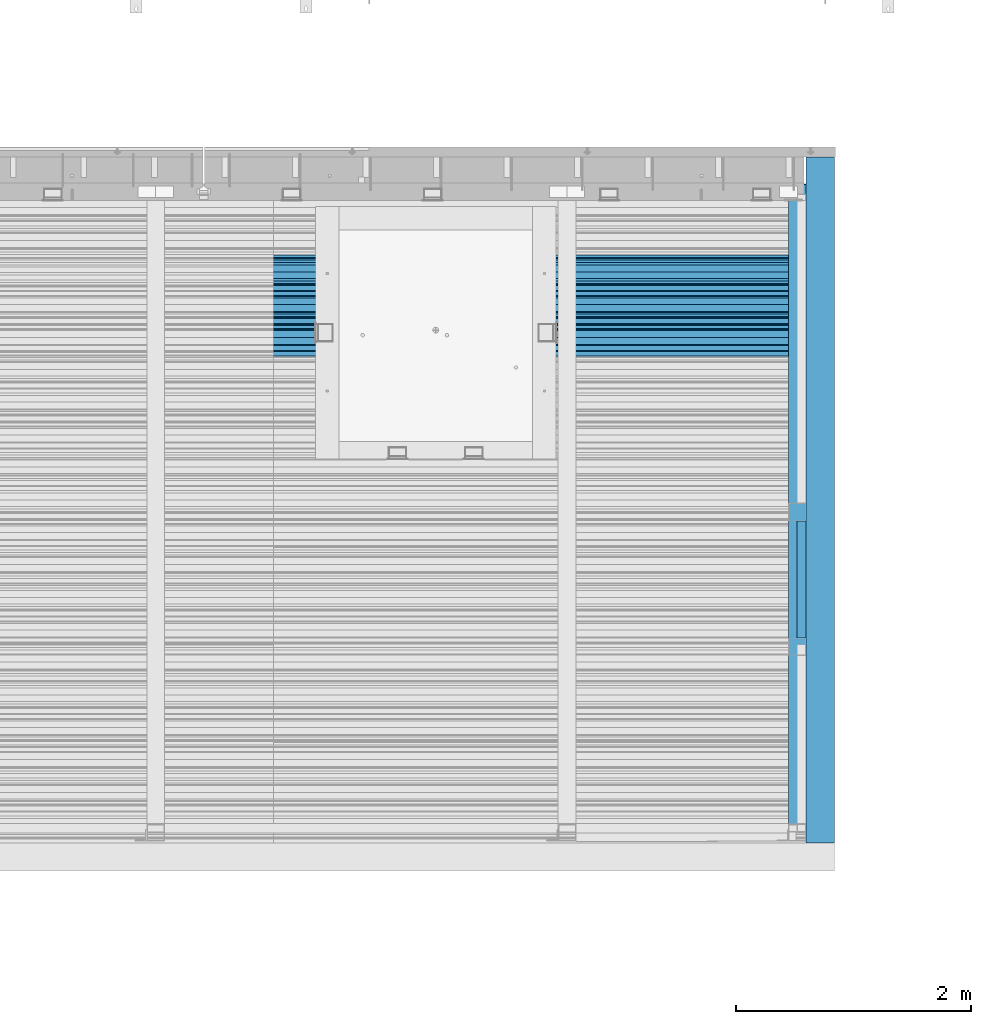
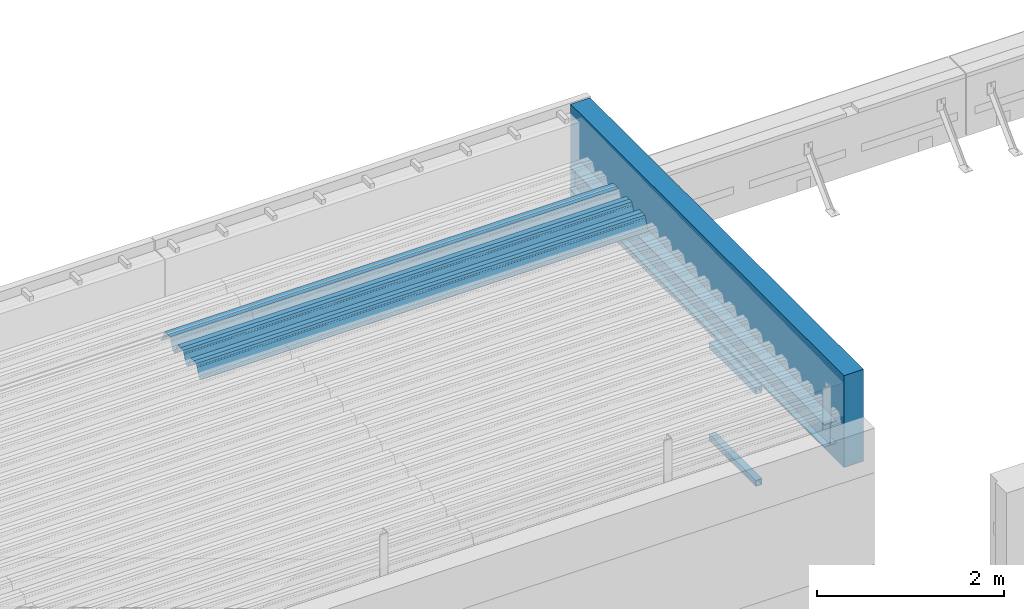
# One storey, part 41 of 153: 5 beams, 5 elements without a shape of their own.
"""IFC2X3 building model written with IfcOpenShell, lengths in millimetres."""

from ifc_helpers import new_model, si_unit, frame, origin_with_axes, place, context, subcontext, project, spatial, faceted_brep, material, type_object, element, aggregate, save


model = new_model("IFC2X3")

# Units and contexts
model_context = context("Model", 3, precision=1e-05, world=origin_with_axes())
body_context = subcontext(model_context, "Body", "Model", "MODEL_VIEW")
ifc_project = project(units=[si_unit("LENGTHUNIT", "METRE", prefix="MILLI"), si_unit("AREAUNIT", "SQUARE_METRE"), si_unit("VOLUMEUNIT", "CUBIC_METRE"), si_unit("MASSUNIT", "GRAM", prefix="KILO"), si_unit("TIMEUNIT", "SECOND"), si_unit("PLANEANGLEUNIT", "RADIAN"), si_unit("SOLIDANGLEUNIT", "STERADIAN"), si_unit("THERMODYNAMICTEMPERATUREUNIT", "DEGREE_CELSIUS"), si_unit("LUMINOUSINTENSITYUNIT", "LUMEN")], contexts=[model_context])

# Site, building, storey
site_placement = place(None, origin_with_axes())
site = spatial("IfcSite", under=ifc_project, at=site_placement, CompositionType="ELEMENT")
building_placement = place(site_placement, origin_with_axes())
building = spatial("IfcBuilding", under=site, at=building_placement, CompositionType="ELEMENT")
storey_placement = place(building_placement, origin_with_axes())
storey = spatial("IfcBuildingStorey", under=building, at=storey_placement, Name="8", CompositionType="ELEMENT", Elevation=0.0)

# Assembly, beam
assembly_1_placement = place(storey_placement, origin_with_axes())
assembly_1 = element("IfcElementAssembly", 1, at=assembly_1_placement, inside=storey, Name="Steel Assembly", AssemblyPlace="NOTDEFINED", PredefinedType="RIGID_FRAME")
ifc_material_1 = material(Name="STEEL/S355J2")
beam_type_1 = type_object("IfcBeamType", Name="80X80X4", PredefinedType="NOTDEFINED")
beam_1_placement = place(assembly_1_placement, frame((21747.0, 16710.0, 105115.0), z_axis=(0.0, 0.0, 1.0), x_axis=(0.0, 1.0, 0.0)))
beam_1 = element("IfcBeam", 2, at=beam_1_placement, type_object=beam_type_1, material=ifc_material_1, ObjectType="80X80X4", context=body_context, shape_type="Brep", body=[
    faceted_brep([(0.0, 36.0, -36.0), (0.0, -36.0, -36.0), (995.0, -36.0, -36.0), (995.0, 36.0, -36.0), (0.0, -36.0, 36.0), (995.0, -36.0, 36.0), (0.0, 36.0, 36.0), (995.0, 36.0, 36.0), (0.0, 40.0, -40.0), (0.0, 40.0, 40.0), (995.0, 40.0, 40.0), (995.0, 40.0, -40.0), (0.0, -40.0, 40.0), (995.0, -40.0, 40.0), (0.0, -40.0, -40.0), (995.0, -40.0, -40.0)], [[[0, 1, 2, 3]], [[1, 4, 5, 2]], [[4, 6, 7, 5]], [[6, 0, 3, 7]], [[8, 9, 10, 11]], [[9, 12, 13, 10]], [[12, 14, 15, 13]], [[14, 8, 11, 15]], [[13, 15, 11, 10], [5, 7, 3, 2]], [[14, 12, 9, 8], [6, 4, 1, 0]]]),
])
aggregate(assembly_1, [beam_1])

assembly_2_placement = place(storey_placement, origin_with_axes())
assembly_2 = element("IfcElementAssembly", 3, at=assembly_2_placement, inside=storey, Name="Steel Assembly", AssemblyPlace="NOTDEFINED", PredefinedType="RIGID_FRAME")
beam_2_placement = place(assembly_2_placement, frame((21747.0, 16710.0, 103915.0), z_axis=(0.0, 0.0, 1.0), x_axis=(0.0, 1.0, 0.0)))
beam_2 = element("IfcBeam", 4, at=beam_2_placement, type_object=beam_type_1, material=ifc_material_1, ObjectType="80X80X4", context=body_context, shape_type="Brep", body=[
    faceted_brep([(0.0, 36.0, -36.0), (0.0, -36.0, -36.0), (995.0, -36.0, -36.0), (995.0, 36.0, -36.0), (0.0, -36.0, 36.0), (995.0, -36.0, 36.0), (0.0, 36.0, 36.0), (995.0, 36.0, 36.0), (0.0, 40.0, -40.0), (0.0, 40.0, 40.0), (995.0, 40.0, 40.0), (995.0, 40.0, -40.0), (0.0, -40.0, 40.0), (995.0, -40.0, 40.0), (0.0, -40.0, -40.0), (995.0, -40.0, -40.0)], [[[0, 1, 2, 3]], [[1, 4, 5, 2]], [[4, 6, 7, 5]], [[6, 0, 3, 7]], [[8, 9, 10, 11]], [[9, 12, 13, 10]], [[12, 14, 15, 13]], [[14, 8, 11, 15]], [[13, 15, 11, 10], [5, 7, 3, 2]], [[14, 12, 9, 8], [6, 4, 1, 0]]]),
])
aggregate(assembly_2, [beam_2])

assembly_3_placement = place(storey_placement, origin_with_axes())
assembly_3 = element("IfcElementAssembly", 5, at=assembly_3_placement, inside=storey, Name="Steel Assembly", AssemblyPlace="NOTDEFINED", PredefinedType="RIGID_FRAME")
beam_type_2 = type_object("IfcBeamType", Name="IPE300", PredefinedType="NOTDEFINED")
beam_3_placement = place(assembly_3_placement, frame((21712.0, 15128.0908589965, 105518.668697995), z_axis=(0.0, -0.0124990270013869, 0.999921884110963), x_axis=(0.0, 0.999921884110963, 0.0124990270013883)))
beam_3 = element("IfcBeam", 6, at=beam_3_placement, type_object=beam_type_2, material=ifc_material_1, ObjectType="IPE300", context=body_context, shape_type="Brep", body=[
    faceted_brep([(3.63797880709171e-12, 75.0, -149.999999999985), (0.0, 75.0, -139.300000189993), (5440.87494889885, 75.0, -139.300000189993), (5440.87494889886, 75.0, -150.0), (0.0, 3.5499999525, -139.300000189993), (5440.87494889885, 3.5499999525, -139.300000189993), (0.0, 3.5499999525, 139.300000190022), (5440.87494889885, 3.5499999525, 139.300000190022), (0.0, 75.0, 139.300000190022), (5440.87494889885, 75.0, 139.300000190022), (3.63797880709171e-12, 75.0, 150.0), (5440.87494889885, 75.0, 150.0), (3.63797880709171e-12, -75.0, 150.0), (5440.87494889885, -75.0, 150.0), (0.0, -75.0, 139.300000190022), (5440.87494889885, -75.0, 139.300000190022), (0.0, -3.5499999525, 139.300000190022), (5440.87494889885, -3.5499999525, 139.300000190022), (0.0, -3.5499999525, -139.300000189993), (5440.87494889885, -3.5499999525, -139.300000189993), (0.0, -75.0, -139.300000189993), (5440.87494889885, -75.0, -139.300000189993), (3.63797880709171e-12, -75.0, -149.999999999985), (5440.87494889886, -75.0, -150.0)], [[[0, 1, 2, 3]], [[1, 4, 5, 2]], [[4, 6, 7, 5]], [[6, 8, 9, 7]], [[8, 10, 11, 9]], [[10, 12, 13, 11]], [[12, 14, 15, 13]], [[14, 16, 17, 15]], [[16, 18, 19, 17]], [[18, 20, 21, 19]], [[20, 22, 23, 21]], [[22, 0, 3, 23]], [[5, 7, 9, 11, 13, 15, 17, 19, 21, 23, 3, 2]], [[22, 20, 18, 16, 14, 12, 10, 8, 6, 4, 1, 0]]]),
])
aggregate(assembly_3, [beam_3])

assembly_4_placement = place(storey_placement, origin_with_axes())
assembly_4 = element("IfcElementAssembly", 7, at=assembly_4_placement, inside=storey, Name="Steel Assembly", AssemblyPlace="NOTDEFINED", PredefinedType="RIGID_FRAME")
beam_type_3 = type_object("IfcBeamType", Name="W", PredefinedType="NOTDEFINED")
beam_4_placement = place(assembly_4_placement, frame((21782.0, 19534.8848733159, 105801.771450287), z_axis=(0.0, -0.0124990270013869, 0.999921884110963), x_axis=(-1.0, 3.00000001838171e-08, 0.0)))
beam_4 = element("IfcBeam", 8, at=beam_4_placement, type_object=beam_type_3, material=ifc_material_1, ObjectType="W", context=body_context, shape_type="Brep", body=[
    faceted_brep([(0.0, -412.839996337891, -77.0100021362159), (0.0, -409.160003662109, -77.0100021362014), (5530.0, -409.160003662109, -77.0100021362014), (5530.0, -412.839996337891, -77.0100021362159), (0.0, -408.070007324222, -73.4800033569045), (5530.0, -408.070007324222, -73.4800033569045), (0.0, -400.339996337894, -48.0600013732619), (5530.0, -400.339996337894, -48.0600013732619), (0.0, -399.459991455082, -46.5600013732619), (5530.0, -399.459991455082, -46.5600013732619), (0.0, -390.329986572269, -36.5499992370314), (5530.0, -390.329986572269, -36.5499992370314), (0.0, -389.19000244141, -34.6300010680861), (5530.0, -389.19000244141, -34.6300010680861), (0.0, -367.820007324222, 35.3400001526024), (5530.0, -367.820007324222, 35.3400001526024), (0.0, -366.989990234379, 36.8499984741502), (5530.0, -366.989990234379, 36.8499984741502), (0.0, -357.809997558597, 46.8600006103807), (5530.0, -357.809997558597, 46.8600006103807), (0.0, -356.720001220707, 48.7700004577782), (5530.0, -356.720001220707, 48.7700004577782), (0.0, -349.309997558594, 73.1500015258935), (5530.0, -349.309997558594, 73.1500015258935), (0.0, -347.850006103516, 75.2300033569481), (5530.0, -347.850006103516, 75.2300033569481), (0.0, -345.470001220707, 76.010002136245), (5530.0, -345.470001220707, 76.010002136245), (0.0, -305.480010986332, 76.010002136245), (5530.0, -305.480010986332, 76.010002136245), (0.0, -304.279998779301, 75.8000030517578), (5530.0, -304.279998779301, 75.8000030517578), (0.0, -291.679992675785, 71.6999969482567), (5530.0, -291.679992675785, 71.6999969482567), (0.0, -290.179992675789, 71.2300033569481), (5530.0, -290.179992675789, 71.2300033569481), (0.0, -288.720001220707, 71.6999969482567), (5530.0, -288.720001220707, 71.6999969482567), (0.0, -276.119995117191, 75.8000030517869), (5530.0, -276.119995117191, 75.8000030517869), (0.0, -274.929992675785, 76.010002136245), (5530.0, -274.929992675785, 76.010002136245), (0.0, -234.94000244141, 76.010002136245), (5530.0, -234.94000244141, 76.010002136245), (0.0, -232.550003051758, 75.2300033569627), (5530.0, -232.550003051758, 75.2300033569627), (0.0, -231.100006103519, 73.1500015258935), (5530.0, -231.100006103519, 73.1500015258935), (0.0, -223.679992675785, 48.7700004577782), (5530.0, -223.679992675785, 48.7700004577782), (0.0, -222.589996337894, 46.8600006103661), (5530.0, -222.589996337894, 46.8600006103661), (0.0, -213.410003662113, 36.8499984741502), (5530.0, -213.410003662113, 36.8499984741502), (0.0, -212.529998779301, 35.3400001526024), (5530.0, -212.529998779301, 35.3400001526024), (0.0, -191.160003662109, -34.6300010681007), (5530.0, -191.160003662109, -34.6300010681007), (0.0, -190.070007324222, -36.5499992370605), (5530.0, -190.070007324222, -36.5499992370605), (0.0, -180.940002441406, -46.560001373291), (5530.0, -180.940002441406, -46.560001373291), (0.0, -180.059997558597, -48.0600013732619), (5530.0, -180.059997558597, -48.0600013732619), (0.0, -172.330001831055, -73.480003356919), (5530.0, -172.330001831055, -73.480003356919), (0.0, -171.240005493168, -77.0100021362159), (5530.0, -171.240005493168, -77.0100021362159), (0.0, -129.330001831062, -77.0100021362014), (5530.0, -129.330001831062, -77.0100021362014), (0.0, -128.300003051761, -73.480003356919), (5530.0, -128.300003051761, -73.480003356919), (0.0, -120.51999664307, -48.0600013732765), (5530.0, -120.51999664307, -48.0600013732765), (0.0, -119.629997253418, -46.5600013732765), (5530.0, -119.629997253418, -46.5600013732765), (0.0, -110.500000000004, -36.5499992370314), (5530.0, -110.500000000004, -36.5499992370314), (0.0, -109.419998168949, -34.6300010680861), (5530.0, -109.419998168949, -34.6300010680861), (0.0, -88.0500030517615, 35.3400001526024), (5530.0, -88.0500030517615, 35.3400001526024), (0.0, -87.160003662113, 36.8499984741356), (5530.0, -87.160003662113, 36.8499984741356), (0.0, -78.0400009155273, 46.8600006103807), (5530.0, -78.0400009155273, 46.8600006103807), (0.0, -76.8899993896557, 48.7700004577782), (5530.0, -76.8899993896557, 48.7700004577782), (0.0, -69.4800033569336, 73.1500015258935), (5530.0, -69.4800033569336, 73.1500015258935), (0.0, -68.0299987793042, 75.2300033569336), (5530.0, -68.0299987793042, 75.2300033569336), (0.0, -65.6399993896521, 76.010002136245), (5530.0, -65.6399993896521, 76.010002136245), (0.0, -25.6499996185375, 76.0100021362596), (5530.0, -25.6499996185375, 76.0100021362596), (0.0, -24.5100002288891, 75.8000030517724), (5530.0, -24.5100002288891, 75.8000030517724), (0.0, -11.8500003814697, 71.6999969482567), (5530.0, -11.8500003814697, 71.6999969482567), (0.0, -10.3999996185339, 71.2300033569481), (5530.0, -10.3999996185339, 71.2300033569481), (0.0, -8.89999961853391, 71.6999969482567), (5530.0, -8.89999961853391, 71.6999969482567), (0.0, 3.71000003814333, 75.8000030517724), (5530.0, 3.71000003814333, 75.8000030517724), (0.0, 4.90000009536379, 76.0100021362596), (5530.0, 4.90000009536379, 76.0100021362596), (0.0, 44.8899993896484, 76.010002136245), (5530.0, 44.8899993896484, 76.010002136245), (0.0, 47.2799987792932, 75.2300033569481), (5530.0, 47.2799987792932, 75.2300033569481), (0.0, 48.6800003051721, 73.1500015258935), (5530.0, 48.6800003051721, 73.1500015258935), (0.0, 56.1500015258753, 48.7700004577782), (5530.0, 56.1500015258753, 48.7700004577782), (0.0, 57.2400016784632, 46.8600006103807), (5530.0, 57.2400016784632, 46.8600006103807), (0.0, 66.3700027465784, 36.8499984741211), (5530.0, 66.3700027465784, 36.8499984741211), (0.0, 67.2499999999964, 35.3400001526024), (5530.0, 67.2499999999964, 35.3400001526024), (0.0, 88.6200027465748, -34.6300010681007), (5530.0, 88.6200027465748, -34.6300010681007), (0.0, 89.709999084469, -36.549999237046), (5530.0, 89.709999084469, -36.549999237046), (0.0, 98.8899993896412, -46.5600013732765), (5530.0, 98.8899993896412, -46.5600013732765), (0.0, 99.7699966430628, -48.0600013732765), (5530.0, 99.7699966430628, -48.0600013732765), (0.0, 107.499999999996, -73.4800033569336), (5530.0, 107.499999999996, -73.4800033569336), (0.0, 108.589996337887, -77.0100021362014), (5530.0, 108.589996337887, -77.0100021362014), (0.0, 112.269996643063, -77.0100021362159), (5530.0, 112.269996643063, -77.0100021362159), (0.0, 146.759994506836, -77.0100021362159), (5530.0, 146.759994506836, -77.0100021362159), (0.0, 150.440002441403, -77.0100021362159), (5530.0, 150.440002441403, -77.0100021362159), (0.0, 151.529998779297, -73.480003356919), (5530.0, 151.529998779297, -73.480003356919), (0.0, 159.30999755859, -48.0600013732765), (5530.0, 159.30999755859, -48.0600013732765), (0.0, 160.190002441406, -46.5600013732619), (5530.0, 160.190002441406, -46.5600013732619), (0.0, 169.320007324215, -36.549999237046), (5530.0, 169.320007324215, -36.549999237046), (0.0, 170.410003662106, -34.6300010680861), (5530.0, 170.410003662106, -34.6300010680861), (0.0, 191.779998779293, 35.3400001526024), (5530.0, 191.779998779293, 35.3400001526024), (0.0, 192.660003662109, 36.8499984741502), (5530.0, 192.660003662109, 36.8499984741502), (0.0, 201.789993286129, 46.8600006103661), (5530.0, 201.789993286129, 46.8600006103661), (0.0, 202.880004882809, 48.7700004577637), (5530.0, 202.880004882809, 48.7700004577637), (0.0, 210.350006103512, 73.150001525908), (5530.0, 210.350006103512, 73.150001525908), (0.0, 211.800003051754, 75.2300033569481), (5530.0, 211.800003051754, 75.2300033569481), (0.0, 214.190002441406, 76.010002136245), (5530.0, 214.190002441406, 76.010002136245), (0.0, 254.179992675778, 76.010002136245), (5530.0, 254.179992675778, 76.010002136245), (0.0, 255.320007324215, 75.8000030517869), (5530.0, 255.320007324215, 75.8000030517869), (0.0, 267.980010986324, 71.6999969482713), (5530.0, 267.980010986324, 71.6999969482713), (0.0, 269.429992675778, 71.2300033569481), (5530.0, 269.429992675778, 71.2300033569481), (0.0, 270.880004882809, 71.6999969482567), (5530.0, 270.880004882809, 71.6999969482567), (0.0, 283.540008544918, 75.8000030517869), (5530.0, 283.540008544918, 75.8000030517869), (0.0, 284.679992675778, 76.010002136245), (5530.0, 284.679992675778, 76.010002136245), (0.0, 324.670013427731, 76.010002136245), (5530.0, 324.670013427731, 76.010002136245), (0.0, 327.049987792969, 75.2300033569627), (5530.0, 327.049987792969, 75.2300033569627), (0.0, 328.510009765625, 73.1500015258789), (5530.0, 328.510009765625, 73.1500015258789), (0.0, 335.980010986324, 48.7700004577782), (5530.0, 335.980010986324, 48.7700004577782), (0.0, 337.05999755859, 46.8600006103661), (5530.0, 337.05999755859, 46.8600006103661), (0.0, 346.190002441399, 36.8499984741356), (5530.0, 346.190002441399, 36.8499984741356), (0.0, 347.079986572266, 35.3400001526024), (5530.0, 347.079986572266, 35.3400001526024), (0.0, 368.450012207028, -34.6300010680861), (5530.0, 368.450012207028, -34.6300010680861), (0.0, 369.529998779293, -36.5499992370314), (5530.0, 369.529998779293, -36.5499992370314), (0.0, 378.660003662106, -46.5600013732619), (5530.0, 378.660003662106, -46.5600013732619), (0.0, 379.540008544918, -48.0600013732619), (5530.0, 379.540008544918, -48.0600013732619), (0.0, 387.329986572262, -73.480003356919), (5530.0, 387.329986572262, -73.480003356919), (0.0, 388.410003662109, -77.0100021362159), (5530.0, 388.410003662109, -77.0100021362159), (0.0, 392.100006103512, -77.0100021362159), (5530.0, 392.100006103512, -77.0100021362159), (0.0, 426.589996337887, -77.0100021362159), (5530.0, 426.589996337887, -77.0100021362159), (0.0, 430.269989013668, -77.0100021362159), (5530.0, 430.269989013668, -77.0100021362159), (0.0, 431.359985351559, -73.4800033569045), (5530.0, 431.359985351559, -73.4800033569045), (0.0, 433.179992675778, -67.5699996948097), (5530.0, 433.179992675778, -67.5699996948097), (0.0, 432.220001220699, -67.2699966430373), (5530.0, 432.220001220699, -67.2699966430373), (0.0, 430.410003662106, -73.1800003051612), (5530.0, 430.410003662106, -73.1800003051612), (0.0, 429.529998779293, -76.0100021362159), (5530.0, 429.529998779293, -76.0100021362159), (0.0, 426.589996337891, -76.0100021362159), (5530.0, 426.589996337891, -76.0100021362159), (0.0, 392.100006103512, -76.0100021362159), (5530.0, 392.100006103512, -76.0100021362159), (0.0, 389.149993896481, -76.0100021362014), (5530.0, 389.149993896481, -76.0100021362014), (0.0, 388.279998779293, -73.1800003051467), (5530.0, 388.279998779293, -73.1800003051467), (0.0, 380.470001220699, -47.659999847383), (5530.0, 380.470001220699, -47.659999847383), (0.0, 379.470001220699, -45.9599990844436), (5530.0, 379.470001220699, -45.9599990844436), (0.0, 370.350006103512, -35.9599990844581), (5530.0, 370.350006103512, -35.9599990844581), (0.0, 369.369995117184, -34.2299995422218), (5530.0, 369.369995117184, -34.2299995422218), (0.0, 347.999999999996, 35.7500000000146), (5530.0, 347.999999999996, 35.7500000000146), (0.0, 346.999999999996, 37.4399986267235), (5530.0, 346.999999999996, 37.4399986267235), (0.0, 337.880004882809, 47.450000762954), (5530.0, 337.880004882809, 47.450000762954), (0.0, 336.899993896481, 49.1699981689453), (5530.0, 336.899993896481, 49.1699981689453), (0.0, 329.420013427731, 73.5999984741356), (5530.0, 329.420013427731, 73.5999984741356), (0.0, 327.679992675781, 76.0699996948533), (5530.0, 327.679992675781, 76.0699996948533), (0.0, 324.829986572262, 77.010002136245), (5530.0, 324.829986572262, 77.010002136245), (0.0, 284.589996337887, 77.010002136245), (5530.0, 284.589996337887, 77.010002136245), (0.0, 283.290008544922, 76.769996643081), (5530.0, 283.290008544922, 76.769996643081), (0.0, 270.570007324215, 72.6500015258935), (5530.0, 270.570007324215, 72.6500015258935), (0.0, 269.429992675781, 72.2799987793114), (5530.0, 269.429992675781, 72.2799987793114), (0.0, 268.279998779293, 72.650001525908), (5530.0, 268.279998779293, 72.650001525908), (0.0, 255.570007324219, 76.769996643081), (5530.0, 255.570007324219, 76.769996643081), (0.0, 254.270004272461, 77.0100021362596), (5530.0, 254.270004272461, 77.0100021362596), (0.0, 214.029998779293, 77.0100021362596), (5530.0, 214.029998779293, 77.0100021362596), (0.0, 211.179992675781, 76.0699996948388), (5530.0, 211.179992675781, 76.0699996948388), (0.0, 209.440002441403, 73.5999984741356), (5530.0, 209.440002441403, 73.5999984741356), (0.0, 201.960006713864, 49.1699981689599), (5530.0, 201.960006713864, 49.1699981689599), (0.0, 200.979995727532, 47.450000762954), (5530.0, 200.979995727532, 47.450000762954), (0.0, 191.850006103508, 37.4399986267235), (5530.0, 191.850006103508, 37.4399986267235), (0.0, 190.860000610352, 35.7500000000146), (5530.0, 190.860000610352, 35.7500000000146), (0.0, 169.49000549316, -34.2299995422218), (5530.0, 169.49000549316, -34.2299995422218), (0.0, 168.509994506832, -35.9599990844581), (5530.0, 168.509994506832, -35.9599990844581), (0.0, 159.380004882805, -45.9599990844436), (5530.0, 159.380004882805, -45.9599990844436), (0.0, 158.389999389645, -47.6599998473976), (5530.0, 158.389999389645, -47.6599998473976), (0.0, 150.580001831051, -73.1800003051612), (5530.0, 150.580001831051, -73.1800003051612), (0.0, 149.710006713864, -76.0100021362159), (5530.0, 149.710006713864, -76.0100021362159), (0.0, 146.759994506836, -76.0100021362159), (5530.0, 146.759994506836, -76.0100021362159), (0.0, 112.269996643063, -76.0100021362159), (5530.0, 112.269996643063, -76.0100021362159), (0.0, 109.319999694821, -76.0100021362159), (5530.0, 109.319999694821, -76.0100021362159), (0.0, 108.449996948239, -73.1900024413917), (5530.0, 108.449996948239, -73.1900024413917), (0.0, 100.690002441406, -47.659999847383), (5530.0, 100.690002441406, -47.659999847383), (0.0, 99.6999969482386, -45.9599990844581), (5530.0, 99.6999969482386, -45.9599990844581), (0.0, 90.5199966430664, -35.9599990844581), (5530.0, 90.5199966430664, -35.9599990844581), (0.0, 89.5400009155273, -34.2299995422218), (5530.0, 89.5400009155273, -34.2299995422218), (0.0, 68.1699981689417, 35.7500000000146), (5530.0, 68.1699981689417, 35.7500000000146), (0.0, 67.1699981689417, 37.4399986267235), (5530.0, 67.1699981689417, 37.4399986267235), (0.0, 58.0499992370569, 47.4500007629686), (5530.0, 58.0499992370569, 47.4500007629686), (0.0, 57.0699996948206, 49.1699981689599), (5530.0, 57.0699996948206, 49.1699981689599), (0.0, 49.5900001525843, 73.5899963379052), (5530.0, 49.5900001525843, 73.5899963379052), (0.0, 47.9099998474085, 76.0699996948388), (5530.0, 47.9099998474085, 76.0699996948388), (0.0, 45.0499992370569, 77.010002136245), (5530.0, 45.0499992370569, 77.010002136245), (0.0, 4.82000017165774, 77.010002136245), (5530.0, 4.82000017165774, 77.010002136245), (0.0, 3.47000002860659, 76.7699966430955), (5530.0, 3.47000002860659, 76.7699966430955), (0.0, -9.19999980926514, 72.6500015258935), (5530.0, -9.19999980926514, 72.6500015258935), (0.0, -10.3900003433264, 72.2799987792969), (5530.0, -10.3900003433264, 72.2799987792969), (0.0, -11.5399999618567, 72.6500015258935), (5530.0, -11.5399999618567, 72.6500015258935), (0.0, -24.2600002288855, 76.769996643081), (5530.0, -24.2600002288855, 76.769996643081), (0.0, -25.559999465946, 77.0100021362596), (5530.0, -25.559999465946, 77.0100021362596), (0.0, -65.8000030517615, 77.0100021362596), (5530.0, -65.8000030517615, 77.0100021362596), (0.0, -68.6500015258862, 76.0699996948533), (5530.0, -68.6500015258862, 76.0699996948533), (0.0, -70.3899993896521, 73.5999984741356), (5530.0, -70.3899993896521, 73.5999984741356), (0.0, -77.8199996948242, 49.1800003051903), (5530.0, -77.8199996948242, 49.1800003051903), (0.0, -78.8399963378943, 47.450000762954), (5530.0, -78.8399963378943, 47.450000762954), (0.0, -87.9700012207031, 37.4399986267235), (5530.0, -87.9700012207031, 37.4399986267235), (0.0, -88.9700012207068, 35.7500000000146), (5530.0, -88.9700012207068, 35.7500000000146), (0.0, -110.339996337894, -34.2299995422218), (5530.0, -110.339996337894, -34.2299995422218), (0.0, -111.319999694828, -35.9599990844581), (5530.0, -111.319999694828, -35.9599990844581), (0.0, -120.440002441406, -45.9599990844436), (5530.0, -120.440002441406, -45.9599990844436), (0.0, -121.44000244141, -47.6599998473976), (5530.0, -121.44000244141, -47.6599998473976), (0.0, -129.250000000004, -73.1900024413771), (5530.0, -129.250000000004, -73.1900024413771), (0.0, -130.080001831062, -76.0100021362159), (5530.0, -130.080001831062, -76.0100021362159), (0.0, -170.5, -76.0100021362014), (5530.0, -170.5, -76.0100021362014), (0.0, -171.380004882816, -73.1900024413917), (5530.0, -171.380004882816, -73.1900024413917), (0.0, -179.139999389652, -47.6599998473976), (5530.0, -179.139999389652, -47.6599998473976), (0.0, -180.130004882816, -45.9599990844581), (5530.0, -180.130004882816, -45.9599990844581), (0.0, -189.259994506836, -35.9599990844581), (5530.0, -189.259994506836, -35.9599990844581), (0.0, -190.240005493168, -34.2299995422218), (5530.0, -190.240005493168, -34.2299995422218), (0.0, -211.610000610355, 35.7500000000146), (5530.0, -211.610000610355, 35.7500000000146), (0.0, -212.600006103519, 37.4399986267381), (5530.0, -212.600006103519, 37.4399986267381), (0.0, -221.779998779301, 47.450000762954), (5530.0, -221.779998779301, 47.450000762954), (0.0, -222.75999450684, 49.1699981689599), (5530.0, -222.75999450684, 49.1699981689599), (0.0, -230.190002441406, 73.5999984741356), (5530.0, -230.190002441406, 73.5999984741356), (0.0, -231.919998168945, 76.0699996948388), (5530.0, -231.919998168945, 76.0699996948388), (0.0, -234.779998779301, 77.010002136245), (5530.0, -234.779998779301, 77.010002136245), (0.0, -275.010009765629, 77.010002136245), (5530.0, -275.010009765629, 77.010002136245), (0.0, -276.359985351563, 76.769996643081), (5530.0, -276.359985351563, 76.769996643081), (0.0, -289.029998779297, 72.6500015258789), (5530.0, -289.029998779297, 72.6500015258789), (0.0, -290.179992675785, 72.2799987793114), (5530.0, -290.179992675785, 72.2799987793114), (0.0, -291.380004882816, 72.650001525908), (5530.0, -291.380004882816, 72.650001525908), (0.0, -304.040008544926, 76.769996643081), (5530.0, -304.040008544926, 76.769996643081), (0.0, -305.390014648441, 77.010002136245), (5530.0, -305.390014648441, 77.010002136245), (0.0, -345.63000488282, 77.0100021362596), (5530.0, -345.63000488282, 77.0100021362596), (0.0, -348.480010986332, 76.0699996948388), (5530.0, -348.480010986332, 76.0699996948388), (0.0, -350.220001220707, 73.5999984741356), (5530.0, -350.220001220707, 73.5999984741356), (0.0, -357.649993896492, 49.1699981689599), (5530.0, -357.649993896492, 49.1699981689599), (0.0, -358.63000488282, 47.450000762954), (5530.0, -358.63000488282, 47.450000762954), (0.0, -367.809997558594, 37.4300003051903), (5530.0, -367.809997558594, 37.4300003051903), (0.0, -368.750000000004, 35.7299995422654), (5530.0, -368.750000000004, 35.7299995422654), (0.0, -390.109985351566, -34.2200012207031), (5530.0, -390.109985351566, -34.2200012207031), (0.0, -391.140014648441, -35.9500007629249), (5530.0, -391.140014648441, -35.9500007629249), (0.0, -400.269989013676, -45.9599990844436), (5530.0, -400.269989013676, -45.9599990844436), (0.0, -401.269989013672, -47.6599998473976), (5530.0, -401.269989013672, -47.6599998473976), (0.0, -409.029998779297, -73.1900024413917), (5530.0, -409.029998779297, -73.1900024413917), (0.0, -409.899993896488, -76.0100021362159), (5530.0, -409.899993896488, -76.0100021362159), (0.0, -412.839996337891, -76.0100021362159), (5530.0, -412.839996337891, -76.0100021362159), (0.0, -433.179992675785, -76.0100021362159), (5530.0, -433.179992675785, -76.0100021362159), (0.0, -433.179992675785, -77.0100021362159), (5530.0, -433.179992675785, -77.0100021362159)], [[[0, 1, 2, 3]], [[1, 4, 5, 2]], [[4, 6, 7, 5]], [[6, 8, 9, 7]], [[8, 10, 11, 9]], [[10, 12, 13, 11]], [[12, 14, 15, 13]], [[14, 16, 17, 15]], [[16, 18, 19, 17]], [[18, 20, 21, 19]], [[20, 22, 23, 21]], [[22, 24, 25, 23]], [[24, 26, 27, 25]], [[26, 28, 29, 27]], [[28, 30, 31, 29]], [[30, 32, 33, 31]], [[32, 34, 35, 33]], [[34, 36, 37, 35]], [[36, 38, 39, 37]], [[38, 40, 41, 39]], [[40, 42, 43, 41]], [[42, 44, 45, 43]], [[44, 46, 47, 45]], [[46, 48, 49, 47]], [[48, 50, 51, 49]], [[50, 52, 53, 51]], [[52, 54, 55, 53]], [[54, 56, 57, 55]], [[56, 58, 59, 57]], [[58, 60, 61, 59]], [[60, 62, 63, 61]], [[62, 64, 65, 63]], [[64, 66, 67, 65]], [[66, 68, 69, 67]], [[68, 70, 71, 69]], [[70, 72, 73, 71]], [[72, 74, 75, 73]], [[74, 76, 77, 75]], [[76, 78, 79, 77]], [[78, 80, 81, 79]], [[80, 82, 83, 81]], [[82, 84, 85, 83]], [[84, 86, 87, 85]], [[86, 88, 89, 87]], [[88, 90, 91, 89]], [[90, 92, 93, 91]], [[92, 94, 95, 93]], [[94, 96, 97, 95]], [[96, 98, 99, 97]], [[98, 100, 101, 99]], [[100, 102, 103, 101]], [[102, 104, 105, 103]], [[104, 106, 107, 105]], [[106, 108, 109, 107]], [[108, 110, 111, 109]], [[110, 112, 113, 111]], [[112, 114, 115, 113]], [[114, 116, 117, 115]], [[116, 118, 119, 117]], [[118, 120, 121, 119]], [[120, 122, 123, 121]], [[122, 124, 125, 123]], [[124, 126, 127, 125]], [[126, 128, 129, 127]], [[128, 130, 131, 129]], [[130, 132, 133, 131]], [[132, 134, 135, 133]], [[134, 136, 137, 135]], [[136, 138, 139, 137]], [[138, 140, 141, 139]], [[140, 142, 143, 141]], [[142, 144, 145, 143]], [[144, 146, 147, 145]], [[146, 148, 149, 147]], [[148, 150, 151, 149]], [[150, 152, 153, 151]], [[152, 154, 155, 153]], [[154, 156, 157, 155]], [[156, 158, 159, 157]], [[158, 160, 161, 159]], [[160, 162, 163, 161]], [[162, 164, 165, 163]], [[164, 166, 167, 165]], [[166, 168, 169, 167]], [[168, 170, 171, 169]], [[170, 172, 173, 171]], [[172, 174, 175, 173]], [[174, 176, 177, 175]], [[176, 178, 179, 177]], [[178, 180, 181, 179]], [[180, 182, 183, 181]], [[182, 184, 185, 183]], [[184, 186, 187, 185]], [[186, 188, 189, 187]], [[188, 190, 191, 189]], [[190, 192, 193, 191]], [[192, 194, 195, 193]], [[194, 196, 197, 195]], [[196, 198, 199, 197]], [[198, 200, 201, 199]], [[200, 202, 203, 201]], [[202, 204, 205, 203]], [[204, 206, 207, 205]], [[206, 208, 209, 207]], [[208, 210, 211, 209]], [[210, 212, 213, 211]], [[212, 214, 215, 213]], [[214, 216, 217, 215]], [[216, 218, 219, 217]], [[218, 220, 221, 219]], [[220, 222, 223, 221]], [[222, 224, 225, 223]], [[224, 226, 227, 225]], [[226, 228, 229, 227]], [[228, 230, 231, 229]], [[230, 232, 233, 231]], [[232, 234, 235, 233]], [[234, 236, 237, 235]], [[236, 238, 239, 237]], [[238, 240, 241, 239]], [[240, 242, 243, 241]], [[242, 244, 245, 243]], [[244, 246, 247, 245]], [[246, 248, 249, 247]], [[248, 250, 251, 249]], [[250, 252, 253, 251]], [[252, 254, 255, 253]], [[254, 256, 257, 255]], [[256, 258, 259, 257]], [[258, 260, 261, 259]], [[260, 262, 263, 261]], [[262, 264, 265, 263]], [[264, 266, 267, 265]], [[266, 268, 269, 267]], [[268, 270, 271, 269]], [[270, 272, 273, 271]], [[272, 274, 275, 273]], [[274, 276, 277, 275]], [[276, 278, 279, 277]], [[278, 280, 281, 279]], [[280, 282, 283, 281]], [[282, 284, 285, 283]], [[284, 286, 287, 285]], [[286, 288, 289, 287]], [[288, 290, 291, 289]], [[290, 292, 293, 291]], [[292, 294, 295, 293]], [[294, 296, 297, 295]], [[296, 298, 299, 297]], [[298, 300, 301, 299]], [[300, 302, 303, 301]], [[302, 304, 305, 303]], [[304, 306, 307, 305]], [[306, 308, 309, 307]], [[308, 310, 311, 309]], [[310, 312, 313, 311]], [[312, 314, 315, 313]], [[314, 316, 317, 315]], [[316, 318, 319, 317]], [[318, 320, 321, 319]], [[320, 322, 323, 321]], [[322, 324, 325, 323]], [[324, 326, 327, 325]], [[326, 328, 329, 327]], [[328, 330, 331, 329]], [[330, 332, 333, 331]], [[332, 334, 335, 333]], [[334, 336, 337, 335]], [[336, 338, 339, 337]], [[338, 340, 341, 339]], [[340, 342, 343, 341]], [[342, 344, 345, 343]], [[344, 346, 347, 345]], [[346, 348, 349, 347]], [[348, 350, 351, 349]], [[350, 352, 353, 351]], [[352, 354, 355, 353]], [[354, 356, 357, 355]], [[356, 358, 359, 357]], [[358, 360, 361, 359]], [[360, 362, 363, 361]], [[362, 364, 365, 363]], [[364, 366, 367, 365]], [[366, 368, 369, 367]], [[368, 370, 371, 369]], [[370, 372, 373, 371]], [[372, 374, 375, 373]], [[374, 376, 377, 375]], [[376, 378, 379, 377]], [[378, 380, 381, 379]], [[380, 382, 383, 381]], [[382, 384, 385, 383]], [[384, 386, 387, 385]], [[386, 388, 389, 387]], [[388, 390, 391, 389]], [[390, 392, 393, 391]], [[392, 394, 395, 393]], [[394, 396, 397, 395]], [[396, 398, 399, 397]], [[398, 400, 401, 399]], [[400, 402, 403, 401]], [[402, 404, 405, 403]], [[404, 406, 407, 405]], [[406, 408, 409, 407]], [[408, 410, 411, 409]], [[410, 412, 413, 411]], [[412, 414, 415, 413]], [[414, 416, 417, 415]], [[416, 418, 419, 417]], [[418, 420, 421, 419]], [[420, 422, 423, 421]], [[422, 424, 425, 423]], [[424, 426, 427, 425]], [[426, 428, 429, 427]], [[428, 430, 431, 429]], [[430, 0, 3, 431]], [[5, 7, 9, 11, 13, 15, 17, 19, 21, 23, 25, 27, 29, 31, 33, 35, 37, 39, 41, 43, 45, 47, 49, 51, 53, 55, 57, 59, 61, 63, 65, 67, 69, 71, 73, 75, 77, 79, 81, 83, 85, 87, 89, 91, 93, 95, 97, 99, 101, 103, 105, 107, 109, 111, 113, 115, 117, 119, 121, 123, 125, 127, 129, 131, 133, 135, 137, 139, 141, 143, 145, 147, 149, 151, 153, 155, 157, 159, 161, 163, 165, 167, 169, 171, 173, 175, 177, 179, 181, 183, 185, 187, 189, 191, 193, 195, 197, 199, 201, 203, 205, 207, 209, 211, 213, 215, 217, 219, 221, 223, 225, 227, 229, 231, 233, 235, 237, 239, 241, 243, 245, 247, 249, 251, 253, 255, 257, 259, 261, 263, 265, 267, 269, 271, 273, 275, 277, 279, 281, 283, 285, 287, 289, 291, 293, 295, 297, 299, 301, 303, 305, 307, 309, 311, 313, 315, 317, 319, 321, 323, 325, 327, 329, 331, 333, 335, 337, 339, 341, 343, 345, 347, 349, 351, 353, 355, 357, 359, 361, 363, 365, 367, 369, 371, 373, 375, 377, 379, 381, 383, 385, 387, 389, 391, 393, 395, 397, 399, 401, 403, 405, 407, 409, 411, 413, 415, 417, 419, 421, 423, 425, 427, 429, 431, 3, 2]], [[430, 428, 426, 424, 422, 420, 418, 416, 414, 412, 410, 408, 406, 404, 402, 400, 398, 396, 394, 392, 390, 388, 386, 384, 382, 380, 378, 376, 374, 372, 370, 368, 366, 364, 362, 360, 358, 356, 354, 352, 350, 348, 346, 344, 342, 340, 338, 336, 334, 332, 330, 328, 326, 324, 322, 320, 318, 316, 314, 312, 310, 308, 306, 304, 302, 300, 298, 296, 294, 292, 290, 288, 286, 284, 282, 280, 278, 276, 274, 272, 270, 268, 266, 264, 262, 260, 258, 256, 254, 252, 250, 248, 246, 244, 242, 240, 238, 236, 234, 232, 230, 228, 226, 224, 222, 220, 218, 216, 214, 212, 210, 208, 206, 204, 202, 200, 198, 196, 194, 192, 190, 188, 186, 184, 182, 180, 178, 176, 174, 172, 170, 168, 166, 164, 162, 160, 158, 156, 154, 152, 150, 148, 146, 144, 142, 140, 138, 136, 134, 132, 130, 128, 126, 124, 122, 120, 118, 116, 114, 112, 110, 108, 106, 104, 102, 100, 98, 96, 94, 92, 90, 88, 86, 84, 82, 80, 78, 76, 74, 72, 70, 68, 66, 64, 62, 60, 58, 56, 54, 52, 50, 48, 46, 44, 42, 40, 38, 36, 34, 32, 30, 28, 26, 24, 22, 20, 18, 16, 14, 12, 10, 8, 6, 4, 1, 0]]]),
])
aggregate(assembly_4, [beam_4])

assembly_5_placement = place(storey_placement, origin_with_axes())
assembly_5 = element("IfcElementAssembly", 9, at=assembly_5_placement, inside=storey, Name="Steel Assembly", AssemblyPlace="NOTDEFINED", PredefinedType="NOTDEFINED")
ifc_material_2 = material()
beam_type_4 = type_object("IfcBeamType", PredefinedType="NOTDEFINED")
beam_5_placement = place(assembly_5_placement, frame((21907.0013586809, 14965.0025069363, 105750.0), z_axis=(0.0, 0.0, 1.0), x_axis=(0.0, 1.0, 0.0)))
beam_5 = element("IfcBeam", 10, at=beam_5_placement, type_object=beam_type_4, material=ifc_material_2, Name="SW", context=body_context, shape_type="Brep", body=[
    faceted_brep([(0.0, 120.0, -600.0), (0.0, 120.0, 600.0), (5834.99749306367, 120.0, 600.0), (5834.99749306367, 120.0, -600.0), (0.0, -120.0, 600.0), (5834.99749306367, -120.0, 600.0), (0.0, -120.0, -600.0), (5834.99749306367, -120.0, -600.0)], [[[0, 1, 2, 3]], [[1, 4, 5, 2]], [[4, 6, 7, 5]], [[6, 0, 3, 7]], [[5, 7, 3, 2]], [[6, 4, 1, 0]]]),
])
aggregate(assembly_5, [beam_5])

save(model, "model.ifc")
